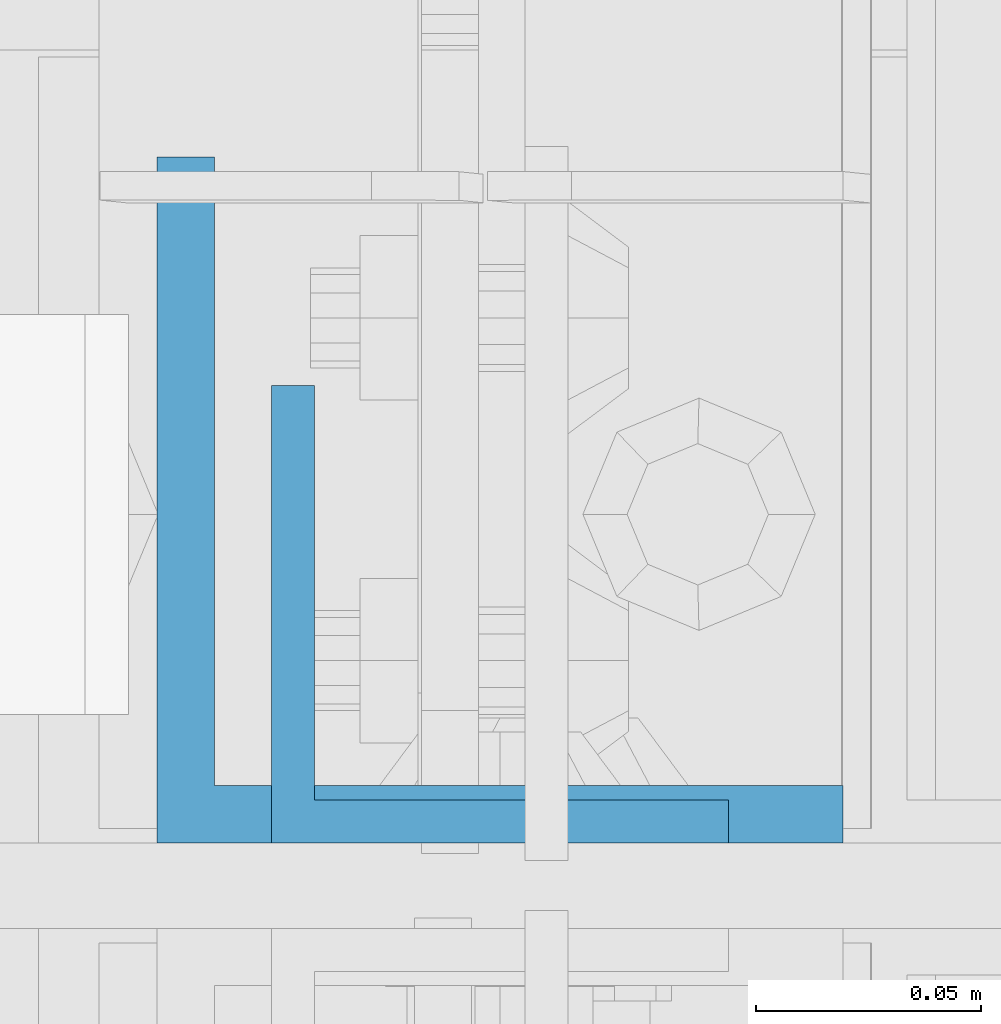
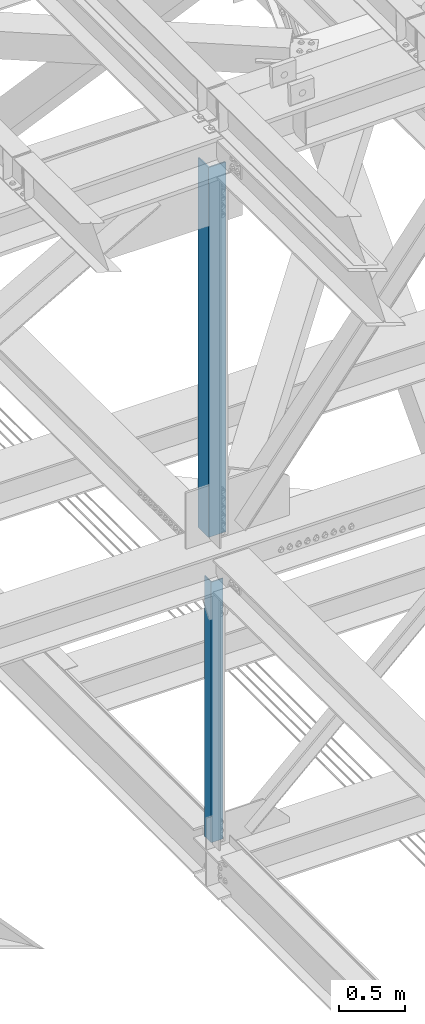
# One storey, part 1925 of 3843: 2 beams, 2 elements without a shape of their own.
"""IFC2X3 building model written with IfcOpenShell, lengths in millimetres."""

from ifc_helpers import new_model, si_unit, frame, origin_with_axes, place, context, subcontext, project, spatial, faceted_brep, material, type_object, element, aggregate, save


model = new_model("IFC2X3")

# Units and contexts
model_context = context("Model", 3, precision=1e-05, world=origin_with_axes())
body_context = subcontext(model_context, "Body", "Model", "MODEL_VIEW")
ifc_project = project(units=[si_unit("LENGTHUNIT", "METRE", prefix="MILLI"), si_unit("AREAUNIT", "SQUARE_METRE"), si_unit("VOLUMEUNIT", "CUBIC_METRE"), si_unit("MASSUNIT", "GRAM", prefix="KILO"), si_unit("TIMEUNIT", "SECOND"), si_unit("PLANEANGLEUNIT", "RADIAN"), si_unit("SOLIDANGLEUNIT", "STERADIAN"), si_unit("THERMODYNAMICTEMPERATUREUNIT", "DEGREE_CELSIUS"), si_unit("LUMINOUSINTENSITYUNIT", "LUMEN")], contexts=[model_context])

# Site, building, storey
site_placement = place(None, origin_with_axes())
site = spatial("IfcSite", under=ifc_project, at=site_placement, CompositionType="ELEMENT")
building_placement = place(site_placement, origin_with_axes())
building = spatial("IfcBuilding", under=site, at=building_placement, Name="Undefined", CompositionType="ELEMENT")
storey_placement = place(building_placement, origin_with_axes())
storey = spatial("IfcBuildingStorey", under=building, at=storey_placement, Name="Undefined", CompositionType="ELEMENT", Elevation=0.0)

# Assembly, beam
assembly_1_placement = place(storey_placement, origin_with_axes())
assembly_1 = element("IfcElementAssembly", 1, at=assembly_1_placement, inside=storey, Name="ANGLE", AssemblyPlace="NOTDEFINED", PredefinedType="RIGID_FRAME")
ifc_material = material(Name="STEEL/A572-50")
beam_type_1 = type_object("IfcBeamType", Name="L4X4X3/8", PredefinedType="NOTDEFINED")
beam_1_placement = place(assembly_1_placement, frame((77012.8000001231, 84045.425, 42266.0734914176), z_axis=(0.0, 1.0, 0.0), x_axis=(0.0, 0.0, -1.0)))
beam_1 = element("IfcBeam", 2, at=beam_1_placement, type_object=beam_type_1, material=ifc_material, Name="ANGLE", ObjectType="L4X4X3/8", context=body_context, shape_type="Brep", body=[
    faceted_brep([(209.574551470876, 50.8000000000029, -50.8000000000029), (209.574551470876, 50.8000000000029, 50.8000000000029), (2603.58821558402, 50.8000000000029, 50.8000000000029), (2603.58821558402, 50.8000000000029, -50.8000000000029), (209.574551470876, 41.2749999999942, 50.8000000000029), (2603.58821558402, 41.2749999999942, 50.8000000000029), (209.574551470876, 41.2749999999942, -41.2750000000015), (2603.58821558402, 41.2749999999942, -41.2750000000015), (209.574551470876, -50.8000000000029, -41.2750000000015), (2603.58821558402, -50.8000000000029, -41.2750000000015), (209.574551470876, -50.8000000000029, -50.8000000000029), (2603.58821558402, -50.8000000000029, -50.8000000000029)], [[[0, 1, 2, 3]], [[1, 4, 5, 2]], [[4, 6, 7, 5]], [[6, 8, 9, 7]], [[8, 10, 11, 9]], [[10, 0, 3, 11]], [[5, 7, 9, 11, 3, 2]], [[10, 8, 6, 4, 1, 0]]]),
])
aggregate(assembly_1, [beam_1])

assembly_2_placement = place(storey_placement, origin_with_axes())
assembly_2 = element("IfcElementAssembly", 3, at=assembly_2_placement, inside=storey, Name="ANGLE", AssemblyPlace="NOTDEFINED", PredefinedType="RIGID_FRAME")
beam_type_2 = type_object("IfcBeamType", Name="L6X6X1/2", PredefinedType="NOTDEFINED")
beam_2_placement = place(assembly_2_placement, frame((77012.7999988756, 84070.825, 46096.5034765807), z_axis=(0.0, 1.0, 0.0), x_axis=(0.0, 0.0, -1.0)))
beam_2 = element("IfcBeam", 4, at=beam_2_placement, type_object=beam_type_2, material=ifc_material, Name="ANGLE", ObjectType="L6X6X1/2", context=body_context, shape_type="Brep", body=[
    faceted_brep([(224.074104126361, 76.1999999990803, -76.1999999999971), (224.074104126361, 76.1999999990803, 76.1999999999971), (3621.49425093896, 76.1999999852123, 76.1999999999971), (3621.49425093896, 76.1999999852123, -76.1999999999971), (224.074104139145, 63.4999999990832, 76.1999999999971), (3621.49425095174, 63.4999999852153, 76.1999999999971), (224.074104139145, 63.4999999990832, -63.5), (3621.49425095174, 63.4999999852153, -63.5), (224.074104279869, -76.2000000009139, -63.5), (3621.49425109247, -76.2000000147818, -63.5), (224.074104279869, -76.2000000009139, -76.1999999999971), (3621.49425109247, -76.2000000147818, -76.1999999999971)], [[[0, 1, 2, 3]], [[1, 4, 5, 2]], [[4, 6, 7, 5]], [[6, 8, 9, 7]], [[8, 10, 11, 9]], [[10, 0, 3, 11]], [[5, 7, 9, 11, 3, 2]], [[10, 8, 6, 4, 1, 0]]]),
])
aggregate(assembly_2, [beam_2])

save(model, "model.ifc")
